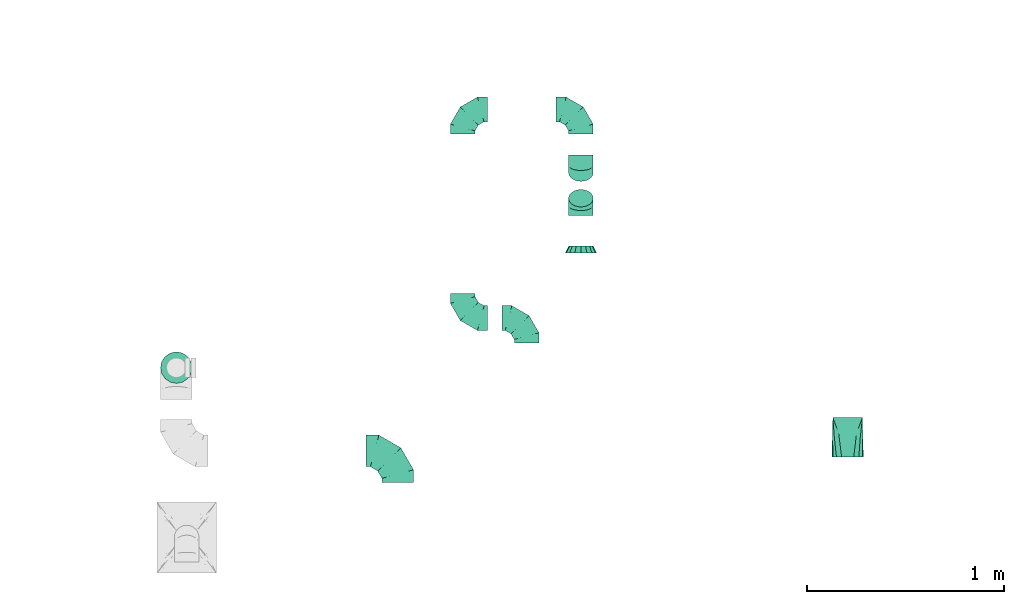
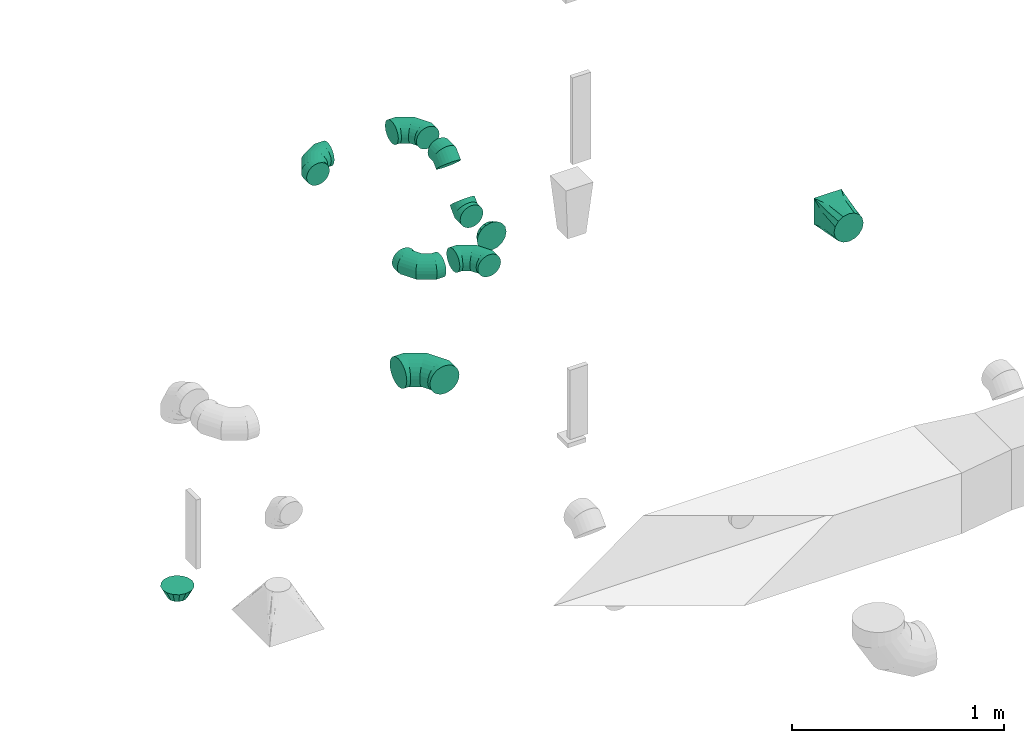
# One storey, part 79 of 97: 10 flow fittings.
"""IFC2X3 building model written with IfcOpenShell, lengths in millimetres."""

from ifc_helpers import new_model, entity, si_unit, converted_unit, derived_unit, direction, frame, origin, place, context, subcontext, project, spatial, faceted_brep, source, transform, mapped, material, type_object, type_shapes, element, save


model = new_model("IFC2X3")

# Units and contexts
model_context = context("Model", 3, precision=0.01, world=origin(), true_north=direction((6.12303176911189e-17, 1.0)))
body_context = subcontext(model_context, "Body", "Model", "MODEL_VIEW")
ifc_project = project(units=[si_unit("LENGTHUNIT", "METRE", prefix="MILLI"), si_unit("AREAUNIT", "SQUARE_METRE"), si_unit("VOLUMEUNIT", "CUBIC_METRE"), converted_unit("PLANEANGLEUNIT", "DEGREE", entity("IfcRatioMeasure", 0.0174532925199433), si_unit("PLANEANGLEUNIT", "RADIAN"), dimensions=[0, 0, 0, 0, 0, 0, 0]), si_unit("MASSUNIT", "GRAM", prefix="KILO"), derived_unit("MASSDENSITYUNIT", [(si_unit("MASSUNIT", "GRAM", prefix="KILO"), 1), (si_unit("LENGTHUNIT", "METRE"), -3)]), derived_unit("MOMENTOFINERTIAUNIT", [(si_unit("LENGTHUNIT", "METRE"), 4)]), si_unit("TIMEUNIT", "SECOND"), si_unit("FREQUENCYUNIT", "HERTZ"), si_unit("THERMODYNAMICTEMPERATUREUNIT", "DEGREE_CELSIUS"), derived_unit("THERMALTRANSMITTANCEUNIT", [(si_unit("MASSUNIT", "GRAM", prefix="KILO"), 1), (si_unit("THERMODYNAMICTEMPERATUREUNIT", "KELVIN"), -1), (si_unit("TIMEUNIT", "SECOND"), -3)]), derived_unit("VOLUMETRICFLOWRATEUNIT", [(si_unit("LENGTHUNIT", "METRE"), 3), (si_unit("TIMEUNIT", "SECOND"), -1)]), derived_unit("MASSFLOWRATEUNIT", [(si_unit("MASSUNIT", "GRAM", prefix="KILO"), 1), (si_unit("TIMEUNIT", "SECOND"), -1)]), derived_unit("ROTATIONALFREQUENCYUNIT", [(si_unit("TIMEUNIT", "SECOND"), -1)]), si_unit("ELECTRICCURRENTUNIT", "AMPERE"), si_unit("ELECTRICVOLTAGEUNIT", "VOLT"), si_unit("POWERUNIT", "WATT"), si_unit("FORCEUNIT", "NEWTON", prefix="KILO"), si_unit("ILLUMINANCEUNIT", "LUX"), si_unit("LUMINOUSFLUXUNIT", "LUMEN"), si_unit("LUMINOUSINTENSITYUNIT", "CANDELA"), derived_unit("USERDEFINED", [(si_unit("MASSUNIT", "GRAM", prefix="KILO"), -1), (si_unit("LENGTHUNIT", "METRE"), -2), (si_unit("TIMEUNIT", "SECOND"), 3), (si_unit("LUMINOUSFLUXUNIT", "LUMEN"), 1)]), derived_unit("LINEARVELOCITYUNIT", [(si_unit("LENGTHUNIT", "METRE"), 1), (si_unit("TIMEUNIT", "SECOND"), -1)]), si_unit("PRESSUREUNIT", "PASCAL"), derived_unit("USERDEFINED", [(si_unit("LENGTHUNIT", "METRE"), -2), (si_unit("MASSUNIT", "GRAM", prefix="KILO"), 1), (si_unit("TIMEUNIT", "SECOND"), -2)]), derived_unit("LINEARFORCEUNIT", [(si_unit("MASSUNIT", "GRAM", prefix="KILO"), 1), (si_unit("LENGTHUNIT", "METRE"), 1), (si_unit("TIMEUNIT", "SECOND"), -2), (si_unit("LENGTHUNIT", "METRE"), -1)]), derived_unit("PLANARFORCEUNIT", [(si_unit("MASSUNIT", "GRAM", prefix="KILO"), 1), (si_unit("LENGTHUNIT", "METRE"), 1), (si_unit("TIMEUNIT", "SECOND"), -2), (si_unit("LENGTHUNIT", "METRE"), -2)])], contexts=[model_context])

# Site, building, storey
site_placement = place(None, origin())
site = spatial("IfcSite", under=ifc_project, at=site_placement, CompositionType="ELEMENT")
building_placement = place(site_placement, origin())
building = spatial("IfcBuilding", under=site, at=building_placement, CompositionType="ELEMENT")
storey_placement = place(building_placement, frame((0.0, 0.0, -4900.0)))
storey = spatial("IfcBuildingStorey", under=building, at=storey_placement, CompositionType="ELEMENT", Elevation=-4900.0)

# Flow fittings
ifc_material = material()
duct_fitting_type_1 = type_object("IfcDuctFittingType", PredefinedType="NOTDEFINED", material=ifc_material)
shared_shape_1 = source(origin(), body_context, "Body", "Brep", [
    faceted_brep([(-160.0, 0.0, -80.0), (-160.0, -20.71, -77.27), (-160.0, -40.0, -69.28), (-160.0, -56.57, -56.57), (-160.0, -69.28, -40.0), (-160.0, -77.27, -20.71), (-160.0, -80.0, 0.0), (-160.0, -77.27, 20.71), (-160.0, -69.28, 40.0), (-160.0, -56.57, 56.57), (-160.0, -40.0, 69.28), (-160.0, -20.71, 77.27), (-160.0, 0.0, 80.0), (-160.0, 20.71, 77.27), (-160.0, 40.0, 69.28), (-160.0, 56.57, 56.57), (-160.0, 69.28, 40.0), (-160.0, 77.27, 20.71), (-160.0, 80.0, 0.0), (-160.0, 77.27, -20.71), (-160.0, 69.28, -40.0), (-160.0, 56.57, -56.57), (-160.0, 40.0, -69.28), (-160.0, 20.71, -77.27), (-122.68, 20.71, 77.27), (-127.85, 40.0, 69.28), (-117.13, 0.0, 80.0), (-132.29, 56.57, 56.57), (-137.83, 77.27, 20.71), (-138.56, 80.0, 0.0), (-135.69, 69.28, 40.0), (-135.69, 69.28, -40.0), (-132.29, 56.57, -56.57), (-137.83, 77.27, -20.71), (-122.68, 20.71, -77.27), (-117.13, 0.0, -80.0), (-127.85, 40.0, -69.28), (-111.58, -20.71, -77.27), (-106.41, -40.0, -69.28), (-101.97, -56.57, -56.57), (-98.56, -69.28, -40.0), (-96.42, -77.27, -20.71), (-95.69, -80.0, 0.0), (-96.42, -77.27, 20.71), (-98.56, -69.28, 40.0), (-101.97, -56.57, 56.57), (-106.41, -40.0, 69.28), (-111.58, -20.71, 77.27), (-58.03, 58.03, 77.27), (-72.15, 72.15, 69.28), (-42.87, 42.87, 80.0), (-84.28, 84.28, 56.57), (-93.59, 93.59, 40.0), (-99.44, 99.44, 20.71), (-101.44, 101.44, 0.0), (-99.44, 99.44, -20.71), (-93.59, 93.59, -40.0), (-84.28, 84.28, -56.57), (-58.03, 58.03, -77.27), (-42.87, 42.87, -80.0), (-72.15, 72.15, -69.28), (-27.71, 27.71, -77.27), (-13.59, 13.59, -69.28), (-1.46, 1.46, -56.57), (7.85, -7.85, -40.0), (13.7, -13.7, -20.71), (15.69, -15.69, 0.0), (13.7, -13.7, 20.71), (7.85, -7.85, 40.0), (-1.46, 1.46, 56.57), (-13.59, 13.59, 69.28), (-27.71, 27.71, 77.27), (-20.71, 122.68, 77.27), (-40.0, 127.85, 69.28), (0.0, 117.13, 80.0), (-56.57, 132.29, 56.57), (-69.28, 135.69, 40.0), (-77.27, 137.83, 20.71), (-80.0, 138.56, 0.0), (-77.27, 137.83, -20.71), (-69.28, 135.69, -40.0), (-56.57, 132.29, -56.57), (-20.71, 122.68, -77.27), (0.0, 117.13, -80.0), (-40.0, 127.85, -69.28), (20.71, 111.58, -77.27), (40.0, 106.41, -69.28), (56.57, 101.97, -56.57), (69.28, 98.56, -40.0), (77.27, 96.42, -20.71), (80.0, 95.69, 0.0), (77.27, 96.42, 20.71), (69.28, 98.56, 40.0), (56.57, 101.97, 56.57), (40.0, 106.41, 69.28), (20.71, 111.58, 77.27), (-20.71, 160.0, -77.27), (-40.0, 160.0, -69.28), (-56.57, 160.0, -56.57), (-69.28, 160.0, -40.0), (-77.27, 160.0, -20.71), (-80.0, 160.0, 0.0), (-77.27, 160.0, 20.71), (-69.28, 160.0, 40.0), (-56.57, 160.0, 56.57), (-40.0, 160.0, 69.28), (-20.71, 160.0, 77.27), (0.0, 160.0, 80.0), (20.71, 160.0, 77.27), (40.0, 160.0, 69.28), (56.57, 160.0, 56.57), (69.28, 160.0, 40.0), (77.27, 160.0, 20.71), (80.0, 160.0, 0.0), (77.27, 160.0, -20.71), (69.28, 160.0, -40.0), (56.57, 160.0, -56.57), (40.0, 160.0, -69.28), (20.71, 160.0, -77.27), (0.0, 160.0, -80.0)], [[[0, 1, 2, 3, 4, 5, 6, 7, 8, 9, 10, 11, 12, 13, 14, 15, 16, 17, 18, 19, 20, 21, 22, 23]], [[24, 25, 14, 13]], [[26, 24, 13, 12]], [[14, 25, 27, 15]], [[28, 29, 18, 17]], [[30, 28, 17, 16]], [[15, 27, 30, 16]], [[20, 31, 32, 21]], [[33, 31, 20, 19]], [[18, 29, 33, 19]], [[34, 35, 0, 23]], [[36, 34, 23, 22]], [[32, 36, 22, 21]], [[1, 0, 35, 37]], [[2, 1, 37, 38]], [[3, 2, 38, 39]], [[5, 4, 40, 41]], [[6, 5, 41, 42]], [[39, 40, 4, 3]], [[6, 42, 43, 7]], [[7, 43, 44, 8]], [[8, 44, 45, 9]], [[9, 45, 46, 10]], [[10, 46, 47, 11]], [[26, 12, 11, 47]], [[48, 49, 25, 24]], [[50, 48, 24, 26]], [[27, 25, 49, 51]], [[52, 53, 28, 30]], [[51, 52, 30, 27]], [[29, 28, 53, 54]], [[55, 56, 31, 33]], [[54, 55, 33, 29]], [[32, 31, 56, 57]], [[58, 59, 35, 34]], [[60, 58, 34, 36]], [[57, 60, 36, 32]], [[37, 35, 59, 61]], [[38, 37, 61, 62]], [[39, 38, 62, 63]], [[41, 40, 64, 65]], [[42, 41, 65, 66]], [[63, 64, 40, 39]], [[43, 42, 66, 67]], [[44, 43, 67, 68]], [[68, 69, 45, 44]], [[46, 45, 69, 70]], [[47, 46, 70, 71]], [[26, 47, 71, 50]], [[72, 73, 49, 48]], [[74, 72, 48, 50]], [[51, 49, 73, 75]], [[76, 77, 53, 52]], [[75, 76, 52, 51]], [[54, 53, 77, 78]], [[79, 80, 56, 55]], [[78, 79, 55, 54]], [[57, 56, 80, 81]], [[82, 83, 59, 58]], [[84, 82, 58, 60]], [[81, 84, 60, 57]], [[61, 59, 83, 85]], [[62, 61, 85, 86]], [[63, 62, 86, 87]], [[65, 64, 88, 89]], [[66, 65, 89, 90]], [[87, 88, 64, 63]], [[67, 66, 90, 91]], [[68, 67, 91, 92]], [[92, 93, 69, 68]], [[70, 69, 93, 94]], [[71, 70, 94, 95]], [[50, 71, 95, 74]], [[96, 97, 98, 99, 100, 101, 102, 103, 104, 105, 106, 107, 108, 109, 110, 111, 112, 113, 114, 115, 116, 117, 118, 119]], [[72, 74, 107, 106]], [[73, 72, 106, 105]], [[75, 73, 105, 104]], [[77, 76, 103, 102]], [[78, 77, 102, 101]], [[75, 104, 103, 76]], [[78, 101, 100, 79]], [[79, 100, 99, 80]], [[80, 99, 98, 81]], [[84, 97, 96, 82]], [[82, 96, 119, 83]], [[84, 81, 98, 97]], [[118, 117, 86, 85]], [[119, 118, 85, 83]], [[116, 87, 86, 117]], [[88, 115, 114, 89]], [[89, 114, 113, 90]], [[115, 88, 87, 116]], [[112, 111, 92, 91]], [[113, 112, 91, 90]], [[111, 110, 93, 92]], [[95, 94, 109, 108]], [[74, 95, 108, 107]], [[110, 109, 94, 93]]]),
])
type_shapes(duct_fitting_type_1, [shared_shape_1])
flow_fitting_1_placement = place(storey_placement, frame((56185.54, 17387.0, 4050.0), z_axis=(0.0, -2.58695510616548e-08, 1.0), x_axis=(0.0, 1.0, 2.58695510616548e-08)))
element("IfcFlowFitting", 1, at=flow_fitting_1_placement, inside=storey, type_object=duct_fitting_type_1, material=ifc_material, context=body_context, shape_type="MappedRepresentation", body=[
    mapped(shared_shape_1, transform((0.0, 0.0, 0.0), scale=1.0)),
])
duct_fitting_type_2 = type_object("IfcDuctFittingType", PredefinedType="NOTDEFINED", material=ifc_material)
shared_shape_2 = source(origin(), body_context, "Body", "Brep", [
    faceted_brep([(-125.0, 0.0, -62.5), (-125.0, -16.18, -60.37), (-125.0, -31.25, -54.13), (-125.0, -44.19, -44.19), (-125.0, -54.13, -31.25), (-125.0, -60.37, -16.18), (-125.0, -62.5, 0.0), (-125.0, -60.37, 16.18), (-125.0, -54.13, 31.25), (-125.0, -44.19, 44.19), (-125.0, -31.25, 54.13), (-125.0, -16.18, 60.37), (-125.0, 0.0, 62.5), (-125.0, 16.18, 60.37), (-125.0, 31.25, 54.13), (-125.0, 44.19, 44.19), (-125.0, 54.13, 31.25), (-125.0, 60.37, 16.18), (-125.0, 62.5, 0.0), (-125.0, 60.37, -16.18), (-125.0, 54.13, -31.25), (-125.0, 44.19, -44.19), (-125.0, 31.25, -54.13), (-125.0, 16.18, -60.37), (-95.84, 16.18, 60.37), (-99.88, 31.25, 54.13), (-91.51, 0.0, 62.5), (-103.35, 44.19, 44.19), (-107.68, 60.37, 16.18), (-108.25, 62.5, 0.0), (-106.01, 54.13, 31.25), (-106.01, 54.13, -31.25), (-103.35, 44.19, -44.19), (-107.68, 60.37, -16.18), (-95.84, 16.18, -60.37), (-91.51, 0.0, -62.5), (-99.88, 31.25, -54.13), (-87.17, -16.18, -60.37), (-83.13, -31.25, -54.13), (-79.66, -44.19, -44.19), (-77.0, -54.13, -31.25), (-75.33, -60.37, -16.18), (-74.76, -62.5, 0.0), (-75.33, -60.37, 16.18), (-77.0, -54.13, 31.25), (-79.66, -44.19, 44.19), (-83.13, -31.25, 54.13), (-87.17, -16.18, 60.37), (-45.34, 45.34, 60.37), (-56.37, 56.37, 54.13), (-33.49, 33.49, 62.5), (-65.85, 65.85, 44.19), (-73.12, 73.12, 31.25), (-77.69, 77.69, 16.18), (-79.25, 79.25, 0.0), (-77.69, 77.69, -16.18), (-73.12, 73.12, -31.25), (-65.85, 65.85, -44.19), (-45.34, 45.34, -60.37), (-33.49, 33.49, -62.5), (-56.37, 56.37, -54.13), (-21.65, 21.65, -60.37), (-10.62, 10.62, -54.13), (-1.14, 1.14, -44.19), (6.13, -6.13, -31.25), (10.7, -10.7, -16.18), (12.26, -12.26, 0.0), (10.7, -10.7, 16.18), (6.13, -6.13, 31.25), (-1.14, 1.14, 44.19), (-10.62, 10.62, 54.13), (-21.65, 21.65, 60.37), (-16.18, 95.84, 60.37), (-31.25, 99.88, 54.13), (0.0, 91.51, 62.5), (-44.19, 103.35, 44.19), (-54.13, 106.01, 31.25), (-60.37, 107.68, 16.18), (-62.5, 108.25, 0.0), (-60.37, 107.68, -16.18), (-54.13, 106.01, -31.25), (-44.19, 103.35, -44.19), (-16.18, 95.84, -60.37), (0.0, 91.51, -62.5), (-31.25, 99.88, -54.13), (16.18, 87.17, -60.37), (31.25, 83.13, -54.13), (44.19, 79.66, -44.19), (54.13, 77.0, -31.25), (60.37, 75.33, -16.18), (62.5, 74.76, 0.0), (60.37, 75.33, 16.18), (54.13, 77.0, 31.25), (44.19, 79.66, 44.19), (31.25, 83.13, 54.13), (16.18, 87.17, 60.37), (-16.18, 125.0, -60.37), (-31.25, 125.0, -54.13), (-44.19, 125.0, -44.19), (-54.13, 125.0, -31.25), (-60.37, 125.0, -16.18), (-62.5, 125.0, 0.0), (-60.37, 125.0, 16.18), (-54.13, 125.0, 31.25), (-44.19, 125.0, 44.19), (-31.25, 125.0, 54.13), (-16.18, 125.0, 60.37), (0.0, 125.0, 62.5), (16.18, 125.0, 60.37), (31.25, 125.0, 54.13), (44.19, 125.0, 44.19), (54.13, 125.0, 31.25), (60.37, 125.0, 16.18), (62.5, 125.0, 0.0), (60.37, 125.0, -16.18), (54.13, 125.0, -31.25), (44.19, 125.0, -44.19), (31.25, 125.0, -54.13), (16.18, 125.0, -60.37), (0.0, 125.0, -62.5)], [[[0, 1, 2, 3, 4, 5, 6, 7, 8, 9, 10, 11, 12, 13, 14, 15, 16, 17, 18, 19, 20, 21, 22, 23]], [[24, 25, 14, 13]], [[26, 24, 13, 12]], [[14, 25, 27, 15]], [[28, 29, 18, 17]], [[30, 28, 17, 16]], [[15, 27, 30, 16]], [[20, 31, 32, 21]], [[33, 31, 20, 19]], [[18, 29, 33, 19]], [[34, 35, 0, 23]], [[36, 34, 23, 22]], [[21, 32, 36, 22]], [[1, 0, 35, 37]], [[2, 1, 37, 38]], [[38, 39, 3, 2]], [[5, 4, 40, 41]], [[6, 5, 41, 42]], [[39, 40, 4, 3]], [[6, 42, 43, 7]], [[7, 43, 44, 8]], [[45, 9, 8, 44]], [[9, 45, 46, 10]], [[10, 46, 47, 11]], [[26, 12, 11, 47]], [[48, 49, 25, 24]], [[50, 48, 24, 26]], [[27, 25, 49, 51]], [[52, 53, 28, 30]], [[51, 52, 30, 27]], [[29, 28, 53, 54]], [[55, 56, 31, 33]], [[54, 55, 33, 29]], [[57, 32, 31, 56]], [[58, 59, 35, 34]], [[60, 58, 34, 36]], [[57, 60, 36, 32]], [[37, 35, 59, 61]], [[38, 37, 61, 62]], [[39, 38, 62, 63]], [[41, 40, 64, 65]], [[42, 41, 65, 66]], [[63, 64, 40, 39]], [[43, 42, 66, 67]], [[44, 43, 67, 68]], [[68, 69, 45, 44]], [[46, 45, 69, 70]], [[47, 46, 70, 71]], [[26, 47, 71, 50]], [[72, 73, 49, 48]], [[74, 72, 48, 50]], [[51, 49, 73, 75]], [[76, 77, 53, 52]], [[75, 76, 52, 51]], [[54, 53, 77, 78]], [[79, 80, 56, 55]], [[78, 79, 55, 54]], [[81, 57, 56, 80]], [[82, 83, 59, 58]], [[84, 82, 58, 60]], [[81, 84, 60, 57]], [[61, 59, 83, 85]], [[62, 61, 85, 86]], [[63, 62, 86, 87]], [[65, 64, 88, 89]], [[66, 65, 89, 90]], [[87, 88, 64, 63]], [[67, 66, 90, 91]], [[68, 67, 91, 92]], [[92, 93, 69, 68]], [[70, 69, 93, 94]], [[71, 70, 94, 95]], [[50, 71, 95, 74]], [[96, 97, 98, 99, 100, 101, 102, 103, 104, 105, 106, 107, 108, 109, 110, 111, 112, 113, 114, 115, 116, 117, 118, 119]], [[72, 74, 107, 106]], [[73, 72, 106, 105]], [[75, 73, 105, 104]], [[77, 76, 103, 102]], [[78, 77, 102, 101]], [[75, 104, 103, 76]], [[78, 101, 100, 79]], [[79, 100, 99, 80]], [[80, 99, 98, 81]], [[96, 119, 83, 82]], [[97, 96, 82, 84]], [[84, 81, 98, 97]], [[83, 119, 118, 85]], [[85, 118, 117, 86]], [[116, 87, 86, 117]], [[88, 115, 114, 89]], [[89, 114, 113, 90]], [[115, 88, 87, 116]], [[91, 90, 113, 112]], [[92, 91, 112, 111]], [[111, 110, 93, 92]], [[95, 94, 109, 108]], [[74, 95, 108, 107]], [[110, 109, 94, 93]]]),
])
type_shapes(duct_fitting_type_2, [shared_shape_2])
for number, where, z_axis, x_axis in (
    (2, (56514.42, 18059.93, 4050.0), (0.0, 0.0, 1.0), (0.0, -1.0, 0.0)),
    (3, (56514.42, 19116.74, 4050.0), (0.0, 0.0, 1.0), (-1.0, 0.0, 0.0)),
    (4, (56838.31, 18059.93, 4050.0), (0.0, 0.0, 1.0), (0.0, 1.0, 0.0)),
    (5, (57113.18, 19116.74, 4050.0), (0.0, 0.0, 1.0), (0.0, 1.0, 0.0)),
):
    element("IfcFlowFitting", number, at=place(storey_placement, frame(where, z_axis=z_axis, x_axis=x_axis)), inside=storey, type_object=duct_fitting_type_2, material=ifc_material, context=body_context, shape_type="MappedRepresentation", body=[
        mapped(shared_shape_2, transform((0.0, 0.0, 0.0), scale=1.0)),
    ])
duct_fitting_type_3 = type_object("IfcDuctFittingType", PredefinedType="NOTDEFINED", material=ifc_material)
shared_shape_3 = source(origin(), body_context, "Body", "Brep", [
    faceted_brep([(35.0, -57.74, 23.92), (35.0, -60.12, 11.96), (35.0, -62.5, 0.0), (35.0, -60.12, -11.96), (35.0, -57.74, -23.92), (35.0, -50.97, -34.06), (35.0, -44.19, -44.19), (35.0, -34.06, -50.97), (35.0, -23.92, -57.74), (35.0, -11.96, -60.12), (35.0, 0.0, -62.5), (35.0, 11.96, -60.12), (35.0, 23.92, -57.74), (35.0, 34.06, -50.97), (35.0, 44.19, -44.19), (35.0, 50.97, -34.06), (35.0, 57.74, -23.92), (35.0, 60.12, -11.96), (35.0, 62.5, 0.0), (35.0, 60.12, 11.96), (35.0, 57.74, 23.92), (35.0, 50.97, 34.06), (35.0, 44.19, 44.19), (35.0, 34.06, 50.97), (35.0, 23.92, 57.74), (35.0, 11.96, 60.12), (35.0, 0.0, 62.5), (35.0, -11.96, 60.12), (35.0, -23.92, 57.74), (35.0, -34.06, 50.97), (35.0, -44.19, 44.19), (35.0, -50.97, 34.06), (0.0, -80.0, 0.0), (0.0, -77.45, 12.81), (0.0, -73.91, 30.61), (0.0, -65.24, 43.59), (0.0, -56.57, 56.57), (0.0, -43.59, 65.24), (0.0, -30.61, 73.91), (0.0, -12.81, 77.45), (0.0, 0.0, 80.0), (0.0, 12.81, 77.45), (0.0, 30.61, 73.91), (0.0, 43.59, 65.24), (0.0, 56.57, 56.57), (0.0, 65.24, 43.59), (0.0, 73.91, 30.61), (0.0, 77.45, 12.81), (0.0, 80.0, 0.0), (0.0, 77.45, -12.81), (0.0, 73.91, -30.61), (0.0, 65.24, -43.59), (0.0, 56.57, -56.57), (0.0, 43.59, -65.24), (0.0, 30.61, -73.91), (0.0, 12.81, -77.45), (0.0, 0.0, -80.0), (0.0, -12.81, -77.45), (0.0, -30.61, -73.91), (0.0, -43.59, -65.24), (0.0, -56.57, -56.57), (0.0, -65.24, -43.59), (0.0, -73.91, -30.61), (0.0, -77.45, -12.81)], [[[0, 1, 2, 3, 4, 5, 6, 7, 8, 9, 10, 11, 12, 13, 14, 15, 16, 17, 18, 19, 20, 21, 22, 23, 24, 25, 26, 27, 28, 29, 30, 31]], [[32, 33, 34, 35, 36, 37, 38, 39, 40, 41, 42, 43, 44, 45, 46, 47, 48, 49, 50, 51, 52, 53, 54, 55, 56, 57, 58, 59, 60, 61, 62, 63]], [[24, 23, 22, 44, 43, 42]], [[20, 46, 45, 44, 22, 21]], [[42, 41, 40, 26, 25, 24]], [[47, 46, 20, 19, 18, 48]], [[0, 31, 30, 36, 35, 34]], [[28, 38, 37, 36, 30, 29]], [[34, 33, 32, 2, 1, 0]], [[39, 38, 28, 27, 26, 40]], [[8, 7, 6, 60, 59, 58]], [[4, 62, 61, 60, 6, 5]], [[58, 57, 56, 10, 9, 8]], [[63, 62, 4, 3, 2, 32]], [[16, 15, 14, 52, 51, 50]], [[12, 54, 53, 52, 14, 13]], [[50, 49, 48, 18, 17, 16]], [[55, 54, 12, 11, 10, 56]]]),
])
type_shapes(duct_fitting_type_3, [shared_shape_3])
flow_fitting_2_placement = place(storey_placement, frame((57113.18, 18388.96, 3847.0), z_axis=(0.0, 0.0, 1.0), x_axis=(0.0, 1.0, 0.0)))
element("IfcFlowFitting", 6, at=flow_fitting_2_placement, inside=storey, type_object=duct_fitting_type_3, material=ifc_material, context=body_context, shape_type="MappedRepresentation", body=[
    mapped(shared_shape_3, transform((0.0, 0.0, 0.0), scale=1.0)),
])
duct_fitting_type_4 = type_object("IfcDuctFittingType", PredefinedType="NOTDEFINED", material=ifc_material)
shared_shape_4 = source(origin(), body_context, "Body", "Brep", [
    faceted_brep([(-51.78, 0.0, -62.5), (-51.78, -16.18, -60.37), (-51.78, -31.25, -54.13), (-51.78, -44.19, -44.19), (-51.78, -54.13, -31.25), (-51.78, -60.37, -16.18), (-51.78, -62.5, 0.0), (-51.78, -60.37, 16.18), (-51.78, -54.13, 31.25), (-51.78, -44.19, 44.19), (-51.78, -31.25, 54.13), (-51.78, -16.18, 60.37), (-51.78, 0.0, 62.5), (-51.78, 16.18, 60.37), (-51.78, 31.25, 54.13), (-51.78, 44.19, 44.19), (-51.78, 54.13, 31.25), (-51.78, 60.37, 16.18), (-51.78, 62.5, 0.0), (-51.78, 60.37, -16.18), (-51.78, 54.13, -31.25), (-51.78, 44.19, -44.19), (-51.78, 31.25, -54.13), (-51.78, 16.18, -60.37), (-6.7, 16.18, 60.37), (-12.94, 31.25, 54.13), (0.0, 0.0, 62.5), (-18.31, 44.19, 44.19), (-22.42, 54.13, 31.25), (-25.01, 60.37, 16.18), (-25.89, 62.5, 0.0), (-25.01, 60.37, -16.18), (-22.42, 54.13, -31.25), (-18.31, 44.19, -44.19), (-6.7, 16.18, -60.37), (0.0, 0.0, -62.5), (-12.94, 31.25, -54.13), (6.7, -16.18, -60.37), (12.94, -31.25, -54.13), (18.31, -44.19, -44.19), (22.42, -54.13, -31.25), (25.01, -60.37, -16.18), (25.89, -62.5, 0.0), (25.01, -60.37, 16.18), (22.42, -54.13, 31.25), (18.31, -44.19, 44.19), (12.94, -31.25, 54.13), (6.7, -16.18, 60.37), (25.17, 48.05, 60.37), (14.51, 58.71, 54.13), (36.61, 36.61, 62.5), (5.36, 67.86, 44.19), (-1.66, 74.88, 31.25), (-6.08, 79.3, 16.18), (-7.58, 80.81, 0.0), (-6.08, 79.3, -16.18), (-1.66, 74.88, -31.25), (5.36, 67.86, -44.19), (14.51, 58.71, -54.13), (25.17, 48.05, -60.37), (36.61, 36.61, -62.5), (48.05, 25.17, -60.37), (58.71, 14.51, -54.13), (67.86, 5.36, -44.19), (74.88, -1.66, -31.25), (79.3, -6.08, -16.18), (80.81, -7.58, 0.0), (79.3, -6.08, 16.18), (74.88, -1.66, 31.25), (67.86, 5.36, 44.19), (58.71, 14.51, 54.13), (48.05, 25.17, 60.37)], [[[0, 1, 2, 3, 4, 5, 6, 7, 8, 9, 10, 11, 12, 13, 14, 15, 16, 17, 18, 19, 20, 21, 22, 23]], [[24, 25, 14, 13]], [[26, 24, 13, 12]], [[27, 15, 14, 25]], [[28, 29, 17, 16]], [[28, 16, 15, 27]], [[30, 18, 17, 29]], [[31, 32, 20, 19]], [[30, 31, 19, 18]], [[21, 20, 32, 33]], [[34, 35, 0, 23]], [[36, 34, 23, 22]], [[33, 36, 22, 21]], [[1, 0, 35, 37]], [[2, 1, 37, 38]], [[38, 39, 3, 2]], [[5, 4, 40, 41]], [[6, 5, 41, 42]], [[39, 40, 4, 3]], [[6, 42, 43, 7]], [[7, 43, 44, 8]], [[8, 44, 45, 9]], [[9, 45, 46, 10]], [[10, 46, 47, 11]], [[26, 12, 11, 47]], [[48, 49, 25, 24]], [[50, 48, 24, 26]], [[27, 25, 49, 51]], [[29, 28, 52, 53]], [[30, 29, 53, 54]], [[51, 52, 28, 27]], [[30, 54, 55, 31]], [[31, 55, 56, 32]], [[57, 33, 32, 56]], [[36, 58, 59, 34]], [[34, 59, 60, 35]], [[58, 36, 33, 57]], [[35, 60, 61, 37]], [[37, 61, 62, 38]], [[63, 39, 38, 62]], [[40, 64, 65, 41]], [[41, 65, 66, 42]], [[64, 40, 39, 63]], [[43, 42, 66, 67]], [[44, 43, 67, 68]], [[68, 69, 45, 44]], [[47, 46, 70, 71]], [[26, 47, 71, 50]], [[69, 70, 46, 45]], [[59, 58, 57, 56, 55, 54, 53, 52, 51, 49, 48, 50, 71, 70, 69, 68, 67, 66, 65, 64, 63, 62, 61, 60]]]),
])
type_shapes(duct_fitting_type_4, [shared_shape_4])
for number, where, z_axis, x_axis in (
    (7, (57113.18, 18630.33, 3847.0), (1.0, 0.0, 0.0), (0.0, 1.0, 0.0)),
    (8, (57113.18, 18833.33, 4050.0), (-1.0, 0.0, 0.0), (0.0, 0.707106781186505, 0.70710678118659)),
):
    element("IfcFlowFitting", number, at=place(storey_placement, frame(where, z_axis=z_axis, x_axis=x_axis)), inside=storey, type_object=duct_fitting_type_4, material=ifc_material, context=body_context, shape_type="MappedRepresentation", body=[
        mapped(shared_shape_4, transform((0.0, 0.0, 0.0), scale=1.0)),
    ])
duct_fitting_type_5 = type_object("IfcDuctFittingType", PredefinedType="NOTDEFINED", material=ifc_material)
shared_shape_5 = source(origin(), body_context, "Body", "Brep", [
    faceted_brep([(200.0, 30.61, 73.91), (200.0, 22.87, 75.45), (200.0, 15.12, 76.99), (200.0, 11.34, 77.74), (200.0, 7.56, 78.5), (200.0, 0.0, 80.0), (200.0, -7.56, 78.5), (200.0, -15.12, 76.99), (200.0, -18.99, 76.22), (200.0, -22.87, 75.45), (200.0, -30.61, 73.91), (200.0, -37.1, 69.57), (200.0, -43.59, 65.24), (200.0, -50.08, 60.9), (200.0, -56.57, 56.57), (200.0, -60.9, 50.08), (200.0, -65.24, 43.59), (200.0, -69.57, 37.1), (200.0, -73.91, 30.61), (200.0, -75.45, 22.87), (200.0, -76.99, 15.12), (200.0, -77.74, 11.34), (200.0, -78.5, 7.56), (200.0, -80.0, 0.0), (200.0, -78.5, -7.56), (200.0, -76.99, -15.12), (200.0, -76.22, -18.99), (200.0, -75.45, -22.87), (200.0, -73.91, -30.61), (200.0, -69.57, -37.1), (200.0, -65.24, -43.59), (200.0, -60.9, -50.08), (200.0, -56.57, -56.57), (200.0, -50.08, -60.9), (200.0, -43.59, -65.24), (200.0, -37.1, -69.57), (200.0, -30.61, -73.91), (200.0, -22.87, -75.45), (200.0, -15.12, -76.99), (200.0, -11.34, -77.74), (200.0, -7.56, -78.5), (200.0, 0.0, -80.0), (200.0, 7.56, -78.5), (200.0, 15.12, -76.99), (200.0, 18.99, -76.22), (200.0, 22.87, -75.45), (200.0, 30.61, -73.91), (200.0, 37.1, -69.57), (200.0, 43.59, -65.24), (200.0, 50.08, -60.9), (200.0, 56.57, -56.57), (200.0, 60.9, -50.08), (200.0, 65.24, -43.59), (200.0, 69.57, -37.1), (200.0, 73.91, -30.61), (200.0, 75.45, -22.87), (200.0, 76.99, -15.12), (200.0, 77.74, -11.34), (200.0, 78.5, -7.56), (200.0, 80.0, 0.0), (200.0, 78.5, 7.56), (200.0, 76.99, 15.12), (200.0, 76.22, 18.99), (200.0, 75.45, 22.87), (200.0, 73.91, 30.61), (200.0, 69.57, 37.1), (200.0, 65.24, 43.59), (200.0, 60.9, 50.08), (200.0, 56.57, 56.57), (200.0, 50.08, 60.9), (200.0, 43.59, 65.24), (200.0, 37.1, 69.57), (0.0, -75.0, 75.0), (0.0, 75.0, 75.0), (0.0, 75.0, -75.0), (0.0, -75.0, -75.0), (52.06, -55.48, 76.3), (78.09, -45.72, 76.95), (176.03, -8.99, 79.4), (152.06, -17.98, 78.8), (128.09, -26.97, 78.2), (104.11, -35.96, 77.6), (100.0, -67.44, 64.02), (78.09, -76.95, 45.72), (104.11, -77.6, 35.96), (128.09, -78.2, 26.97), (152.06, -78.8, 17.98), (164.04, -79.1, 13.48), (176.03, -79.4, 8.99), (26.03, -75.65, 65.24), (52.06, -76.3, 55.48), (26.03, -65.24, 75.65), (26.03, -75.65, -65.24), (52.06, -76.3, -55.48), (78.09, -76.95, -45.72), (104.11, -77.6, -35.96), (128.09, -78.2, -26.97), (152.06, -78.8, -17.98), (176.03, -79.4, -8.99), (100.0, -64.02, -67.44), (78.09, -45.72, -76.95), (104.11, -35.96, -77.6), (128.09, -26.97, -78.2), (152.06, -17.98, -78.8), (164.04, -13.48, -79.1), (176.03, -8.99, -79.4), (26.03, -65.24, -75.65), (52.06, -55.48, -76.3), (26.03, 65.24, -75.65), (52.06, 55.48, -76.3), (78.09, 45.72, -76.95), (104.11, 35.96, -77.6), (128.09, 26.97, -78.2), (152.06, 17.98, -78.8), (176.03, 8.99, -79.4), (100.0, 67.44, -64.02), (78.09, 76.95, -45.72), (104.11, 77.6, -35.96), (128.09, 78.2, -26.97), (152.06, 78.8, -17.98), (164.04, 79.1, -13.48), (176.03, 79.4, -8.99), (26.03, 75.65, -65.24), (52.06, 76.3, -55.48), (26.03, 75.65, 65.24), (52.06, 76.3, 55.48), (78.09, 76.95, 45.72), (104.11, 77.6, 35.96), (128.09, 78.2, 26.97), (152.06, 78.8, 17.98), (176.03, 79.4, 8.99), (100.0, 64.02, 67.44), (78.09, 45.72, 76.95), (104.11, 35.96, 77.6), (128.09, 26.97, 78.2), (152.06, 17.98, 78.8), (164.04, 13.48, 79.1), (176.03, 8.99, 79.4), (26.03, 65.24, 75.65), (52.06, 55.48, 76.3)], [[[0, 1, 2, 3, 4, 5, 6, 7, 8, 9, 10, 11, 12, 13, 14, 15, 16, 17, 18, 19, 20, 21, 22, 23, 24, 25, 26, 27, 28, 29, 30, 31, 32, 33, 34, 35, 36, 37, 38, 39, 40, 41, 42, 43, 44, 45, 46, 47, 48, 49, 50, 51, 52, 53, 54, 55, 56, 57, 58, 59, 60, 61, 62, 63, 64, 65, 66, 67, 68, 69, 70, 71]], [[72, 73, 74, 75]], [[76, 12, 77]], [[12, 11, 10, 77]], [[78, 79, 80, 81, 77, 10, 9, 8, 7, 6, 5]], [[13, 82, 14]], [[20, 19, 18, 83, 84, 85, 86, 87, 88, 23, 22, 21]], [[82, 72, 89]], [[82, 15, 14]], [[83, 16, 90]], [[91, 72, 82]], [[18, 17, 16, 83]], [[90, 16, 15]], [[15, 82, 89]], [[90, 15, 89]], [[76, 13, 12]], [[13, 76, 91]], [[82, 13, 91]], [[88, 87, 86, 85, 84, 83, 90, 89, 72, 75, 92, 93, 94, 95, 96, 97, 98, 23]], [[93, 30, 94]], [[30, 29, 28, 94]], [[98, 97, 96, 95, 94, 28, 27, 26, 25, 24, 23]], [[31, 99, 32]], [[38, 37, 36, 100, 101, 102, 103, 104, 105, 41, 40, 39]], [[99, 75, 106]], [[99, 33, 32]], [[100, 34, 107]], [[92, 75, 99]], [[36, 35, 34, 100]], [[107, 34, 33]], [[33, 99, 106]], [[107, 33, 106]], [[93, 31, 30]], [[31, 93, 92]], [[99, 31, 92]], [[105, 104, 103, 102, 101, 100, 107, 106, 75, 74, 108, 109, 110, 111, 112, 113, 114, 41]], [[109, 48, 110]], [[48, 47, 46, 110]], [[114, 113, 112, 111, 110, 46, 45, 44, 43, 42, 41]], [[49, 115, 50]], [[56, 55, 54, 116, 117, 118, 119, 120, 121, 59, 58, 57]], [[115, 74, 122]], [[115, 51, 50]], [[116, 52, 123]], [[108, 74, 115]], [[54, 53, 52, 116]], [[123, 52, 51]], [[51, 115, 122]], [[123, 51, 122]], [[109, 49, 48]], [[49, 109, 108]], [[115, 49, 108]], [[74, 73, 124, 125, 126, 127, 128, 129, 130, 59, 121, 120, 119, 118, 117, 116, 123, 122]], [[125, 66, 126]], [[66, 65, 64, 126]], [[130, 129, 128, 127, 126, 64, 63, 62, 61, 60, 59]], [[67, 131, 68]], [[2, 1, 0, 132, 133, 134, 135, 136, 137, 5, 4, 3]], [[131, 73, 138]], [[131, 69, 68]], [[132, 70, 139]], [[124, 73, 131]], [[0, 71, 70, 132]], [[139, 70, 69]], [[69, 131, 138]], [[139, 69, 138]], [[125, 67, 66]], [[67, 125, 124]], [[131, 67, 124]], [[73, 72, 91, 76, 77, 81, 80, 79, 78, 5, 137, 136, 135, 134, 133, 132, 139, 138]]]),
])
type_shapes(duct_fitting_type_5, [shared_shape_5])
flow_fitting_3_placement = place(storey_placement, frame((58464.14, 17556.57, 4050.0), z_axis=(0.0, -1.3665540065153e-08, 1.0), x_axis=(0.0, -1.0, -1.3665540065153e-08)))
element("IfcFlowFitting", 9, at=flow_fitting_3_placement, inside=storey, type_object=duct_fitting_type_5, material=ifc_material, context=body_context, shape_type="MappedRepresentation", body=[
    mapped(shared_shape_5, transform((0.0, 0.0, 0.0), scale=1.0)),
])
duct_fitting_type_6 = type_object("IfcDuctFittingType", PredefinedType="NOTDEFINED", material=ifc_material)
shared_shape_6 = source(origin(), body_context, "Body", "Brep", [
    faceted_brep([(60.0, 0.0, -80.0), (60.0, 14.27, -77.16), (60.0, 30.61, -73.91), (60.0, 43.59, -65.24), (60.0, 56.57, -56.57), (60.0, 65.24, -43.59), (60.0, 73.91, -30.61), (60.0, 77.16, -14.27), (60.0, 80.0, 0.0), (60.0, 77.16, 14.27), (60.0, 73.91, 30.61), (60.0, 65.24, 43.59), (60.0, 56.57, 56.57), (60.0, 43.59, 65.24), (60.0, 30.61, 73.91), (60.0, 14.27, 77.16), (60.0, 0.0, 80.0), (60.0, -14.27, 77.16), (60.0, -30.61, 73.91), (60.0, -43.59, 65.24), (60.0, -56.57, 56.57), (60.0, -65.24, 43.59), (60.0, -73.91, 30.61), (60.0, -77.16, 14.27), (60.0, -80.0, 0.0), (60.0, -77.16, -14.27), (60.0, -73.91, -30.61), (60.0, -65.24, -43.59), (60.0, -56.57, -56.57), (60.0, -43.59, -65.24), (60.0, -30.61, -73.91), (60.0, -14.27, -77.16), (0.0, -19.13, -46.19), (0.0, -27.24, -40.77), (0.0, -35.36, -35.36), (0.0, -40.77, -27.24), (0.0, -46.19, -19.13), (0.0, -48.1, -9.57), (0.0, -50.0, 0.0), (0.0, -48.1, 9.57), (0.0, -46.19, 19.13), (0.0, -40.77, 27.24), (0.0, -35.36, 35.36), (0.0, -27.24, 40.77), (0.0, -19.13, 46.19), (0.0, -9.57, 48.1), (0.0, 0.0, 50.0), (0.0, 9.57, 48.1), (0.0, 19.13, 46.19), (0.0, 27.24, 40.77), (0.0, 35.36, 35.36), (0.0, 40.77, 27.24), (0.0, 46.19, 19.13), (0.0, 48.1, 9.57), (0.0, 50.0, 0.0), (0.0, 48.1, -9.57), (0.0, 46.19, -19.13), (0.0, 40.77, -27.24), (0.0, 35.36, -35.36), (0.0, 27.24, -40.77), (0.0, 19.13, -46.19), (0.0, 9.57, -48.1), (0.0, 0.0, -50.0), (0.0, -9.57, -48.1)], [[[0, 1, 2, 3, 4, 5, 6, 7, 8, 9, 10, 11, 12, 13, 14, 15, 16, 17, 18, 19, 20, 21, 22, 23, 24, 25, 26, 27, 28, 29, 30, 31]], [[32, 33, 34, 35, 36, 37, 38, 39, 40, 41, 42, 43, 44, 45, 46, 47, 48, 49, 50, 51, 52, 53, 54, 55, 56, 57, 58, 59, 60, 61, 62, 63]], [[52, 51, 50, 12, 11, 10]], [[48, 14, 13, 12, 50, 49]], [[10, 9, 8, 54, 53, 52]], [[15, 14, 48, 47, 46, 16]], [[44, 43, 42, 20, 19, 18]], [[40, 22, 21, 20, 42, 41]], [[18, 17, 16, 46, 45, 44]], [[23, 22, 40, 39, 38, 24]], [[36, 35, 34, 28, 27, 26]], [[32, 30, 29, 28, 34, 33]], [[26, 25, 24, 38, 37, 36]], [[31, 30, 32, 63, 62, 0]], [[60, 59, 58, 4, 3, 2]], [[56, 6, 5, 4, 58, 57]], [[2, 1, 0, 62, 61, 60]], [[7, 6, 56, 55, 54, 8]]]),
])
type_shapes(duct_fitting_type_6, [shared_shape_6])
flow_fitting_4_placement = place(storey_placement, frame((55064.27, 17808.79, 2845.0), z_axis=(-1.0, 0.0, 0.0), x_axis=(0.0, 0.0, 1.0)))
element("IfcFlowFitting", 10, at=flow_fitting_4_placement, inside=storey, type_object=duct_fitting_type_6, material=ifc_material, context=body_context, shape_type="MappedRepresentation", body=[
    mapped(shared_shape_6, transform((0.0, 0.0, 0.0), scale=1.0)),
])

save(model, "model.ifc")
